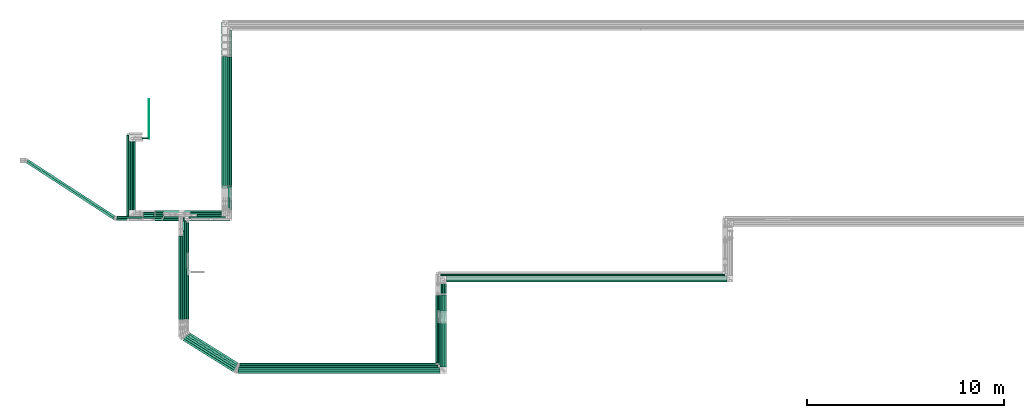
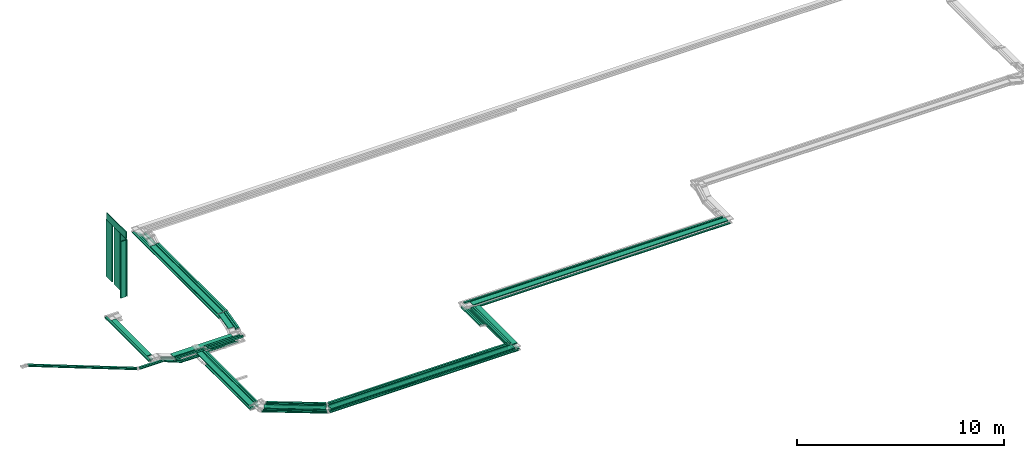
# One storey, part 1 of 14: 72 flow segments.
"""IFC2X3 building model written with IfcOpenShell, lengths in millimetres."""

from ifc_helpers import new_model, entity, si_unit, converted_unit, derived_unit, direction, frame, frame_2d, origin, origin_2d_with_axis, place, context, subcontext, project, spatial, rectangle, extrude, type_object, element, save


model = new_model("IFC2X3")

# Units and contexts
model_context = context("Model", 3, precision=0.01, world=origin(), true_north=direction((6.12303176911189e-17, 1.0)))
body_context = subcontext(model_context, "Body", "Model", "MODEL_VIEW")
ifc_project = project(units=[si_unit("LENGTHUNIT", "METRE", prefix="MILLI"), si_unit("AREAUNIT", "SQUARE_METRE"), si_unit("VOLUMEUNIT", "CUBIC_METRE"), converted_unit("PLANEANGLEUNIT", "DEGREE", entity("IfcRatioMeasure", 0.0174532925199433), si_unit("PLANEANGLEUNIT", "RADIAN"), dimensions=[0, 0, 0, 0, 0, 0, 0]), si_unit("MASSUNIT", "GRAM", prefix="KILO"), derived_unit("MASSDENSITYUNIT", [(si_unit("MASSUNIT", "GRAM", prefix="KILO"), 1), (si_unit("LENGTHUNIT", "METRE"), -3)]), derived_unit("MOMENTOFINERTIAUNIT", [(si_unit("LENGTHUNIT", "METRE"), 4)]), si_unit("TIMEUNIT", "SECOND"), si_unit("FREQUENCYUNIT", "HERTZ"), si_unit("THERMODYNAMICTEMPERATUREUNIT", "DEGREE_CELSIUS"), derived_unit("THERMALTRANSMITTANCEUNIT", [(si_unit("MASSUNIT", "GRAM", prefix="KILO"), 1), (si_unit("THERMODYNAMICTEMPERATUREUNIT", "KELVIN"), -1), (si_unit("TIMEUNIT", "SECOND"), -3)]), derived_unit("VOLUMETRICFLOWRATEUNIT", [(si_unit("LENGTHUNIT", "METRE"), 3), (si_unit("TIMEUNIT", "SECOND"), -1)]), derived_unit("MASSFLOWRATEUNIT", [(si_unit("MASSUNIT", "GRAM", prefix="KILO"), 1), (si_unit("TIMEUNIT", "SECOND"), -1)]), derived_unit("ROTATIONALFREQUENCYUNIT", [(si_unit("TIMEUNIT", "SECOND"), -1)]), si_unit("ELECTRICCURRENTUNIT", "AMPERE"), si_unit("ELECTRICVOLTAGEUNIT", "VOLT"), si_unit("POWERUNIT", "WATT"), si_unit("FORCEUNIT", "NEWTON", prefix="KILO"), si_unit("ILLUMINANCEUNIT", "LUX"), si_unit("LUMINOUSFLUXUNIT", "LUMEN"), si_unit("LUMINOUSINTENSITYUNIT", "CANDELA"), derived_unit("USERDEFINED", [(si_unit("MASSUNIT", "GRAM", prefix="KILO"), -1), (si_unit("LENGTHUNIT", "METRE"), -2), (si_unit("TIMEUNIT", "SECOND"), 3), (si_unit("LUMINOUSFLUXUNIT", "LUMEN"), 1)]), derived_unit("LINEARVELOCITYUNIT", [(si_unit("LENGTHUNIT", "METRE"), 1), (si_unit("TIMEUNIT", "SECOND"), -1)]), si_unit("PRESSUREUNIT", "PASCAL"), derived_unit("USERDEFINED", [(si_unit("LENGTHUNIT", "METRE"), -2), (si_unit("MASSUNIT", "GRAM", prefix="KILO"), 1), (si_unit("TIMEUNIT", "SECOND"), -2)]), derived_unit("LINEARFORCEUNIT", [(si_unit("MASSUNIT", "GRAM", prefix="KILO"), 1), (si_unit("LENGTHUNIT", "METRE"), 1), (si_unit("TIMEUNIT", "SECOND"), -2), (si_unit("LENGTHUNIT", "METRE"), -1)]), derived_unit("PLANARFORCEUNIT", [(si_unit("MASSUNIT", "GRAM", prefix="KILO"), 1), (si_unit("LENGTHUNIT", "METRE"), 1), (si_unit("TIMEUNIT", "SECOND"), -2), (si_unit("LENGTHUNIT", "METRE"), -2)])], contexts=[model_context])

# Site, building, storey
site_placement = place(None, origin())
site = spatial("IfcSite", under=ifc_project, at=site_placement, CompositionType="ELEMENT")
building_placement = place(site_placement, origin())
building = spatial("IfcBuilding", under=site, at=building_placement, CompositionType="ELEMENT")
storey_placement = place(building_placement, frame((0.0, 0.0, 19800.0)))
storey = spatial("IfcBuildingStorey", under=building, at=storey_placement, Name="06", CompositionType="ELEMENT", Elevation=19800.0)

# Flow segments
cable_carrier_segment_type_1 = type_object("IfcCableCarrierSegmentType", PredefinedType="CABLETRAYSEGMENT")
flow_segment_1_placement = place(storey_placement, frame((20190.22, 11603.0, 3300.0)))
element("IfcFlowSegment", 1, at=flow_segment_1_placement, inside=storey, type_object=cable_carrier_segment_type_1, context=body_context, shape_type="SweptSolid", body=[
    extrude(rectangle(XDim=6551.54787533766, YDim=300.000000000001, at=origin_2d_with_axis()), frame((150.0, 3275.77, 0.0), z_axis=(0.0, 0.0, 1.0), x_axis=(0.0, 1.0, 0.0)), (0.0, 0.0, 1.0), 49.9999999999973),
])
flow_segment_2_placement = place(storey_placement, frame((20495.22, 11609.12, 3300.0)))
element("IfcFlowSegment", 2, at=flow_segment_2_placement, inside=storey, type_object=cable_carrier_segment_type_1, context=body_context, shape_type="SweptSolid", body=[
    extrude(rectangle(XDim=6531.55992167095, YDim=100.000000000003, at=origin_2d_with_axis()), frame((50.0, 3265.78, 0.0), z_axis=(0.0, 0.0, 1.0), x_axis=(0.0, 1.0, 0.0)), (0.0, 0.0, 1.0), 100.000000000003),
])
flow_segment_3_placement = place(storey_placement, frame((20600.22, 11501.25, 3100.0)))
element("IfcFlowSegment", 3, at=flow_segment_3_placement, inside=storey, type_object=cable_carrier_segment_type_1, context=body_context, shape_type="SweptSolid", body=[
    extrude(rectangle(XDim=7968.74949015567, YDim=100.000000000003, at=origin_2d_with_axis()), frame((50.0, 3984.37, 0.0), z_axis=(0.0, 0.0, 1.0), x_axis=(0.0, -1.0, 0.0)), (0.0, 0.0, 1.0), 100.000000000003),
])
flow_segment_4_placement = place(storey_placement, frame((20190.22, 11493.51, 3100.0)))
element("IfcFlowSegment", 4, at=flow_segment_4_placement, inside=storey, type_object=cable_carrier_segment_type_1, context=body_context, shape_type="SweptSolid", body=[
    extrude(rectangle(XDim=8386.48782817678, YDim=100.000000000003, at=origin_2d_with_axis()), frame((50.0, 4193.24, 0.0), z_axis=(0.0, 0.0, 1.0), x_axis=(0.0, -1.0, 0.0)), (0.0, 0.0, 1.0), 49.9999999999973),
])
flow_segment_5_placement = place(storey_placement, frame((20295.22, 11493.51, 3100.0)))
element("IfcFlowSegment", 5, at=flow_segment_5_placement, inside=storey, type_object=cable_carrier_segment_type_1, context=body_context, shape_type="SweptSolid", body=[
    extrude(rectangle(XDim=8281.48782817677, YDim=100.000000000003, at=origin_2d_with_axis()), frame((50.0, 4140.74, 0.0), z_axis=(0.0, 0.0, 1.0), x_axis=(0.0, -1.0, 0.0)), (0.0, 0.0, 1.0), 49.9999999999973),
])
flow_segment_6_placement = place(storey_placement, frame((20400.22, 11493.51, 3100.0)))
element("IfcFlowSegment", 6, at=flow_segment_6_placement, inside=storey, type_object=cable_carrier_segment_type_1, context=body_context, shape_type="SweptSolid", body=[
    extrude(rectangle(XDim=8176.48782817679, YDim=100.000000000003, at=origin_2d_with_axis()), frame((50.0, 4088.24, 0.0), z_axis=(0.0, 0.0, 1.0), x_axis=(0.0, -1.0, 0.0)), (0.0, 0.0, 1.0), 49.9999999999973),
])
flow_segment_7_placement = place(storey_placement, frame((18157.54, 10050.13, 2900.0)))
element("IfcFlowSegment", 7, at=flow_segment_7_placement, inside=storey, type_object=cable_carrier_segment_type_1, context=body_context, shape_type="SweptSolid", body=[
    extrude(rectangle(XDim=2012.67275358651, YDim=300.000000000001, at=origin_2d_with_axis()), frame((1006.34, 150.0, 0.0), z_axis=(0.0, 0.0, 1.0), x_axis=(-1.0, 0.0, 0.0)), (0.0, 0.0, 1.0), 49.9999999999973),
])
flow_segment_8_placement = place(storey_placement, frame((18522.14, 9944.24, 2900.0)))
element("IfcFlowSegment", 8, at=flow_segment_8_placement, inside=storey, type_object=cable_carrier_segment_type_1, context=body_context, shape_type="SweptSolid", body=[
    extrude(rectangle(XDim=1953.07275358647, YDim=99.9999999999989, at=origin_2d_with_axis()), frame((976.54, 50.0, 0.0), z_axis=(0.0, 0.0, 1.0), x_axis=(-1.0, 0.0, 0.0)), (0.0, 0.0, 1.0), 100.000000000003),
])
flow_segment_9_placement = place(storey_placement, frame((16789.0, 9824.22, 2900.0)))
element("IfcFlowSegment", 9, at=flow_segment_9_placement, inside=storey, type_object=cable_carrier_segment_type_1, context=body_context, shape_type="SweptSolid", body=[
    extrude(rectangle(XDim=1677.74327889368, YDim=99.9999999999989, at=origin_2d_with_axis()), frame((838.87, 50.0, 0.0)), (0.0, 0.0, 1.0), 100.000000000003),
])
flow_segment_10_placement = place(storey_placement, frame((17191.35, 9840.23, 2600.0)))
element("IfcFlowSegment", 10, at=flow_segment_10_placement, inside=storey, type_object=cable_carrier_segment_type_1, context=body_context, shape_type="SweptSolid", body=[
    extrude(rectangle(XDim=1095.79181857732, YDim=99.9999999999989, at=origin_2d_with_axis()), frame((547.9, 50.0, 0.0)), (0.0, 0.0, 1.0), 49.9999999999973),
])
flow_segment_11_placement = place(storey_placement, frame((17256.59, 9944.24, 2600.0)))
element("IfcFlowSegment", 11, at=flow_segment_11_placement, inside=storey, type_object=cable_carrier_segment_type_1, context=body_context, shape_type="SweptSolid", body=[
    extrude(rectangle(XDim=3123.62777329295, YDim=99.9999999999989, at=origin_2d_with_axis()), frame((1561.81, 50.0, 0.0), z_axis=(0.0, 0.0, 1.0), x_axis=(-1.0, 0.0, 0.0)), (0.0, 0.0, 1.0), 50.0000000000016),
])
flow_segment_12_placement = place(storey_placement, frame((31591.43, 6717.78, 2800.0)))
element("IfcFlowSegment", 12, at=flow_segment_12_placement, inside=storey, type_object=cable_carrier_segment_type_1, context=body_context, shape_type="SweptSolid", body=[
    extrude(rectangle(XDim=14204.952720189, YDim=300.000000000001, at=origin_2d_with_axis()), frame((7102.48, 150.0, 0.0), z_axis=(0.0, 0.0, 1.0), x_axis=(-1.0, 0.0, 0.0)), (0.0, 0.0, 1.0), 49.9999999999973),
])
flow_segment_13_placement = place(storey_placement, frame((31280.61, 7021.93, 2800.0)))
element("IfcFlowSegment", 13, at=flow_segment_13_placement, inside=storey, type_object=cable_carrier_segment_type_1, context=body_context, shape_type="SweptSolid", body=[
    extrude(rectangle(XDim=14408.678815753, YDim=100.000000000001, at=origin_2d_with_axis()), frame((7204.34, 50.0, 0.0), z_axis=(0.0, 0.0, 1.0), x_axis=(-1.0, 0.0, 0.0)), (0.0, 0.0, 1.0), 100.000000000003),
])
flow_segment_14_placement = place(storey_placement, frame((31591.43, 6717.78, 2600.0)))
element("IfcFlowSegment", 14, at=flow_segment_14_placement, inside=storey, type_object=cable_carrier_segment_type_1, context=body_context, shape_type="SweptSolid", body=[
    extrude(rectangle(XDim=14323.3274230858, YDim=99.9999999999989, at=origin_2d_with_axis()), frame((7161.66, 50.0, 0.0), z_axis=(0.0, 0.0, 1.0), x_axis=(-1.0, 0.0, 0.0)), (0.0, 0.0, 1.0), 50.0000000000016),
])
flow_segment_15_placement = place(storey_placement, frame((21062.59, 2392.27, 3200.0)))
element("IfcFlowSegment", 15, at=flow_segment_15_placement, inside=storey, type_object=cable_carrier_segment_type_1, context=body_context, shape_type="SweptSolid", body=[
    extrude(rectangle(XDim=10078.0137037583, YDim=100.0, at=origin_2d_with_axis()), frame((5039.01, 50.0, 0.0), z_axis=(0.0, 0.0, 1.0), x_axis=(-1.0, 0.0, 0.0)), (0.0, 0.0, 1.0), 100.000000000008),
])
flow_segment_16_placement = place(storey_placement, frame((20986.65, 2192.27, 3000.0)))
element("IfcFlowSegment", 16, at=flow_segment_16_placement, inside=storey, type_object=cable_carrier_segment_type_1, context=body_context, shape_type="SweptSolid", body=[
    extrude(rectangle(XDim=10354.846485042, YDim=100.0, at=origin_2d_with_axis()), frame((5177.42, 50.0, 0.0), z_axis=(0.0, 0.0, 1.0), x_axis=(-1.0, 0.0, 0.0)), (0.0, 0.0, 1.0), 49.9999999999973),
])
flow_segment_17_placement = place(storey_placement, frame((18007.14, 4795.41, 2800.0)))
element("IfcFlowSegment", 17, at=flow_segment_17_placement, inside=storey, type_object=cable_carrier_segment_type_1, context=body_context, shape_type="SweptSolid", body=[
    extrude(rectangle(XDim=5199.72119742787, YDim=300.000000000001, at=origin_2d_with_axis()), frame((150.0, 2599.86, 0.0), z_axis=(0.0, 0.0, 1.0), x_axis=(0.0, 1.0, 0.0)), (0.0, 0.0, 1.0), 49.9999999999973),
])
flow_segment_18_placement = place(storey_placement, frame((18312.14, 4839.93, 2800.0)))
element("IfcFlowSegment", 18, at=flow_segment_18_placement, inside=storey, type_object=cable_carrier_segment_type_1, context=body_context, shape_type="SweptSolid", body=[
    extrude(rectangle(XDim=5127.14874316907, YDim=99.9999999999989, at=origin_2d_with_axis()), frame((50.0, 2563.57, 0.0), z_axis=(0.0, 0.0, 1.0), x_axis=(0.0, 1.0, 0.0)), (0.0, 0.0, 1.0), 100.000000000003),
])
flow_segment_19_placement = place(storey_placement, frame((18417.14, 8193.95, 2600.0)))
element("IfcFlowSegment", 19, at=flow_segment_19_placement, inside=storey, type_object=cable_carrier_segment_type_1, context=body_context, shape_type="SweptSolid", body=[
    extrude(rectangle(XDim=1516.27528069827, YDim=99.9999999999989, at=origin_2d_with_axis()), frame((50.0, 758.14, 0.0), z_axis=(0.0, 0.0, 1.0), x_axis=(0.0, -1.0, 0.0)), (0.0, 0.0, 1.0), 50.0000000000016),
])
flow_segment_20_placement = place(storey_placement, frame((18007.14, 4732.08, 2600.0)))
element("IfcFlowSegment", 20, at=flow_segment_20_placement, inside=storey, type_object=cable_carrier_segment_type_1, context=body_context, shape_type="SweptSolid", body=[
    extrude(rectangle(XDim=4319.69591813559, YDim=99.9999999999989, at=origin_2d_with_axis()), frame((50.0, 2159.85, 0.0), z_axis=(0.0, 0.0, 1.0), x_axis=(0.0, 1.0, 0.0)), (0.0, 0.0, 1.0), 49.9999999999973),
])
flow_segment_21_placement = place(storey_placement, frame((18112.14, 4732.08, 2600.0)))
element("IfcFlowSegment", 21, at=flow_segment_21_placement, inside=storey, type_object=cable_carrier_segment_type_1, context=body_context, shape_type="SweptSolid", body=[
    extrude(rectangle(XDim=4319.6959181356, YDim=99.9999999999989, at=origin_2d_with_axis()), frame((50.0, 2159.85, 0.0), z_axis=(0.0, 0.0, 1.0), x_axis=(0.0, 1.0, 0.0)), (0.0, 0.0, 1.0), 49.9999999999973),
])
flow_segment_22_placement = place(storey_placement, frame((18217.14, 4732.08, 2600.0)))
element("IfcFlowSegment", 22, at=flow_segment_22_placement, inside=storey, type_object=cable_carrier_segment_type_1, context=body_context, shape_type="SweptSolid", body=[
    extrude(rectangle(XDim=4546.36734918782, YDim=99.9999999999989, at=origin_2d_with_axis()), frame((50.0, 2273.18, 0.0), z_axis=(0.0, 0.0, 1.0), x_axis=(0.0, 1.0, 0.0)), (0.0, 0.0, 1.0), 49.9999999999973),
])
flow_segment_23_placement = place(storey_placement, frame((31125.11, 2617.27, 3000.0)))
element("IfcFlowSegment", 23, at=flow_segment_23_placement, inside=storey, type_object=cable_carrier_segment_type_1, context=body_context, shape_type="SweptSolid", body=[
    extrude(rectangle(XDim=2031.89362716771, YDim=100.000000000003, at=origin_2d_with_axis()), frame((50.0, 1015.95, 0.0), z_axis=(0.0, 0.0, 1.0), x_axis=(0.0, 1.0, 0.0)), (0.0, 0.0, 1.0), 99.9999999999989),
])
flow_segment_24_placement = place(storey_placement, frame((31125.11, 5296.63, 2600.0)))
element("IfcFlowSegment", 24, at=flow_segment_24_placement, inside=storey, type_object=cable_carrier_segment_type_1, context=body_context, shape_type="SweptSolid", body=[
    extrude(rectangle(XDim=1808.36637507826, YDim=100.000000000003, at=origin_2d_with_axis()), frame((50.0, 904.18, 0.0), z_axis=(0.0, 0.0, 1.0), x_axis=(0.0, 1.0, 0.0)), (0.0, 0.0, 1.0), 100.000000000003),
])
flow_segment_25_placement = place(storey_placement, frame((31249.29, 5245.16, 2600.0)))
element("IfcFlowSegment", 25, at=flow_segment_25_placement, inside=storey, type_object=cable_carrier_segment_type_1, context=body_context, shape_type="SweptSolid", body=[
    extrude(rectangle(XDim=1662.61404192942, YDim=100.000000000003, at=origin_2d_with_axis()), frame((50.0, 831.31, 0.0), z_axis=(0.0, 0.0, 1.0), x_axis=(0.0, -1.0, 0.0)), (0.0, 0.0, 1.0), 49.9999999999973),
])
flow_segment_26_placement = place(storey_placement, frame((31249.29, 2417.27, 3000.0)))
element("IfcFlowSegment", 26, at=flow_segment_26_placement, inside=storey, type_object=cable_carrier_segment_type_1, context=body_context, shape_type="SweptSolid", body=[
    extrude(rectangle(XDim=2211.95486644315, YDim=100.000000000003, at=origin_2d_with_axis()), frame((50.0, 1105.98, 0.0), z_axis=(0.0, 0.0, 1.0), x_axis=(0.0, 1.0, 0.0)), (0.0, 0.0, 1.0), 49.9999999999973),
])
flow_segment_27_placement = place(storey_placement, frame((31361.5, 5245.16, 2600.0)))
element("IfcFlowSegment", 27, at=flow_segment_27_placement, inside=storey, type_object=cable_carrier_segment_type_1, context=body_context, shape_type="SweptSolid", body=[
    extrude(rectangle(XDim=1557.61404192941, YDim=100.000000000003, at=origin_2d_with_axis()), frame((50.0, 778.81, 0.0), z_axis=(0.0, 0.0, 1.0), x_axis=(0.0, -1.0, 0.0)), (0.0, 0.0, 1.0), 49.9999999999973),
])
flow_segment_28_placement = place(storey_placement, frame((31361.5, 2312.27, 3000.0)))
element("IfcFlowSegment", 28, at=flow_segment_28_placement, inside=storey, type_object=cable_carrier_segment_type_1, context=body_context, shape_type="SweptSolid", body=[
    extrude(rectangle(XDim=2316.95486644316, YDim=100.000000000003, at=origin_2d_with_axis()), frame((50.0, 1158.48, 0.0), z_axis=(0.0, 0.0, 1.0), x_axis=(0.0, -1.0, 0.0)), (0.0, 0.0, 1.0), 49.9999999999973),
])
flow_segment_29_placement = place(storey_placement, frame((31471.43, 5245.16, 2600.0)))
element("IfcFlowSegment", 29, at=flow_segment_29_placement, inside=storey, type_object=cable_carrier_segment_type_1, context=body_context, shape_type="SweptSolid", body=[
    extrude(rectangle(XDim=1452.61404192941, YDim=100.000000000003, at=origin_2d_with_axis()), frame((50.0, 726.31, 0.0), z_axis=(0.0, 0.0, 1.0), x_axis=(0.0, -1.0, 0.0)), (0.0, 0.0, 1.0), 49.9999999999973),
])
flow_segment_30_placement = place(storey_placement, frame((31471.43, 2207.27, 3000.0)))
element("IfcFlowSegment", 30, at=flow_segment_30_placement, inside=storey, type_object=cable_carrier_segment_type_1, context=body_context, shape_type="SweptSolid", body=[
    extrude(rectangle(XDim=2421.95486644317, YDim=100.000000000003, at=origin_2d_with_axis()), frame((50.0, 1210.98, 0.0), z_axis=(0.0, 0.0, 1.0), x_axis=(0.0, 1.0, 0.0)), (0.0, 0.0, 1.0), 49.9999999999973),
])
flow_segment_31_placement = place(storey_placement, frame((31271.43, 2407.27, 3200.0)))
element("IfcFlowSegment", 31, at=flow_segment_31_placement, inside=storey, type_object=cable_carrier_segment_type_1, context=body_context, shape_type="SweptSolid", body=[
    extrude(rectangle(XDim=3662.65856661165, YDim=300.000000000001, at=origin_2d_with_axis()), frame((150.0, 1831.33, 0.0), z_axis=(0.0, 0.0, 1.0), x_axis=(0.0, 1.0, 0.0)), (0.0, 0.0, 1.0), 49.9999999999973),
])
flow_segment_32_placement = place(storey_placement, frame((31160.61, 2512.27, 3200.0)))
element("IfcFlowSegment", 32, at=flow_segment_32_placement, inside=storey, type_object=cable_carrier_segment_type_1, context=body_context, shape_type="SweptSolid", body=[
    extrude(rectangle(XDim=3526.8936271677, YDim=100.000000000003, at=origin_2d_with_axis()), frame((50.0, 1763.45, 0.0), z_axis=(0.0, 0.0, 1.0), x_axis=(0.0, 1.0, 0.0)), (0.0, 0.0, 1.0), 100.000000000003),
])
flow_segment_33_placement = place(storey_placement, frame((31047.89, 2620.0, 3200.0)))
element("IfcFlowSegment", 33, at=flow_segment_33_placement, inside=storey, type_object=cable_carrier_segment_type_1, context=body_context, shape_type="SweptSolid", body=[
    extrude(rectangle(XDim=3419.24047842777, YDim=100.000000000003, at=origin_2d_with_axis()), frame((50.0, 1709.62, 0.0), z_axis=(0.0, 0.0, 1.0), x_axis=(0.0, 1.0, 0.0)), (0.0, 0.0, 1.0), 100.000000000008),
])
flow_segment_34_placement = place(storey_placement, frame((21097.29, 2497.27, 3000.0)))
element("IfcFlowSegment", 34, at=flow_segment_34_placement, inside=storey, type_object=cable_carrier_segment_type_1, context=body_context, shape_type="SweptSolid", body=[
    extrude(rectangle(XDim=10007.8208838715, YDim=100.0, at=origin_2d_with_axis()), frame((5003.91, 50.0, 0.0), z_axis=(0.0, 0.0, 1.0), x_axis=(-1.0, 0.0, 0.0)), (0.0, 0.0, 1.0), 100.000000000003),
])
flow_segment_35_placement = place(storey_placement, frame((18430.51, 2430.79, 3200.0)))
element("IfcFlowSegment", 35, at=flow_segment_35_placement, inside=storey, type_object=cable_carrier_segment_type_1, context=body_context, shape_type="SweptSolid", body=[
    extrude(rectangle(XDim=2945.29672939392, YDim=100.000000000004, at=origin_2d_with_axis()), frame((1275.37, 822.79, 0.0), z_axis=(0.0, 0.0, 1.0), x_axis=(-0.848048096156423, 0.52991926423321, 0.0)), (0.0, 0.0, 1.0), 100.000000000003),
])
flow_segment_36_placement = place(storey_placement, frame((21014.25, 2297.27, 3000.0)))
element("IfcFlowSegment", 36, at=flow_segment_36_placement, inside=storey, type_object=cable_carrier_segment_type_1, context=body_context, shape_type="SweptSolid", body=[
    extrude(rectangle(XDim=10215.0397317824, YDim=100.0, at=origin_2d_with_axis()), frame((5107.52, 50.0, 0.0), z_axis=(0.0, 0.0, 1.0), x_axis=(-1.0, 0.0, 0.0)), (0.0, 0.0, 1.0), 49.9999999999973),
])
flow_segment_37_placement = place(storey_placement, frame((20950.04, 2087.27, 3000.0)))
element("IfcFlowSegment", 37, at=flow_segment_37_placement, inside=storey, type_object=cable_carrier_segment_type_1, context=body_context, shape_type="SweptSolid", body=[
    extrude(rectangle(XDim=10501.3978164659, YDim=100.0, at=origin_2d_with_axis()), frame((5250.7, 50.0, 0.0), z_axis=(0.0, 0.0, 1.0), x_axis=(-1.0, 0.0, 0.0)), (0.0, 0.0, 1.0), 49.9999999999973),
])
flow_segment_38_placement = place(storey_placement, frame((18125.51, 2125.79, 3000.0)))
element("IfcFlowSegment", 38, at=flow_segment_38_placement, inside=storey, type_object=cable_carrier_segment_type_1, context=body_context, shape_type="SweptSolid", body=[
    extrude(rectangle(XDim=3172.2205568259, YDim=100.000000000005, at=origin_2d_with_axis()), frame((1371.59, 882.91, 0.0), z_axis=(0.0, 0.0, 1.0), x_axis=(-0.848048096156423, 0.52991926423321, 0.0)), (0.0, 0.0, 1.0), 49.9999999999973),
])
flow_segment_39_placement = place(storey_placement, frame((21002.32, 2087.27, 3200.0)))
element("IfcFlowSegment", 39, at=flow_segment_39_placement, inside=storey, type_object=cable_carrier_segment_type_1, context=body_context, shape_type="SweptSolid", body=[
    extrude(rectangle(XDim=10249.1129852784, YDim=300.0, at=origin_2d_with_axis()), frame((5124.56, 150.0, 0.0), z_axis=(0.0, 0.0, 1.0), x_axis=(-1.0, 0.0, 0.0)), (0.0, 0.0, 1.0), 49.9999999999973),
])
flow_segment_40_placement = place(storey_placement, frame((21092.92, 2500.0, 3200.0)))
element("IfcFlowSegment", 40, at=flow_segment_40_placement, inside=storey, type_object=cable_carrier_segment_type_1, context=body_context, shape_type="SweptSolid", body=[
    extrude(rectangle(XDim=9934.97609200436, YDim=100.0, at=origin_2d_with_axis()), frame((4967.49, 50.0, 0.0), z_axis=(0.0, 0.0, 1.0), x_axis=(-1.0, 0.0, 0.0)), (0.0, 0.0, 1.0), 100.000000000008),
])
flow_segment_41_placement = place(storey_placement, frame((18535.51, 2538.52, 3200.0)))
element("IfcFlowSegment", 41, at=flow_segment_41_placement, inside=storey, type_object=cable_carrier_segment_type_1, context=body_context, shape_type="SweptSolid", body=[
    extrude(rectangle(XDim=2857.23886438621, YDim=100.000000000005, at=origin_2d_with_axis()), frame((1238.03, 799.46, 0.0), z_axis=(0.0, 0.0, 1.0), x_axis=(-0.84804809615642, 0.529919264233215, 0.0)), (0.0, 0.0, 1.0), 100.000000000003),
])
flow_segment_42_placement = place(storey_placement, frame((18230.51, 2230.79, 3000.0)))
element("IfcFlowSegment", 42, at=flow_segment_42_placement, inside=storey, type_object=cable_carrier_segment_type_1, context=body_context, shape_type="SweptSolid", body=[
    extrude(rectangle(XDim=3091.5847138092, YDim=100.000000000005, at=origin_2d_with_axis()), frame((1337.4, 861.55, 0.0), z_axis=(0.0, 0.0, 1.0), x_axis=(-0.848048096156424, 0.529919264233208, 0.0)), (0.0, 0.0, 1.0), 49.9999999999973),
])
flow_segment_43_placement = place(storey_placement, frame((18335.51, 2335.79, 3000.0)))
element("IfcFlowSegment", 43, at=flow_segment_43_placement, inside=storey, type_object=cable_carrier_segment_type_1, context=body_context, shape_type="SweptSolid", body=[
    extrude(rectangle(XDim=3000.30868914057, YDim=100.000000000005, at=origin_2d_with_axis()), frame((1298.7, 837.36, 0.0), z_axis=(0.0, 0.0, 1.0), x_axis=(-0.848048096156424, 0.529919264233208, 0.0)), (0.0, 0.0, 1.0), 49.9999999999973),
])
flow_segment_44_placement = place(storey_placement, frame((18535.51, 2535.79, 3000.0)))
element("IfcFlowSegment", 44, at=flow_segment_44_placement, inside=storey, type_object=cable_carrier_segment_type_1, context=body_context, shape_type="SweptSolid", body=[
    extrude(rectangle(XDim=2862.39408159168, YDim=99.9999999999956, at=origin_2d_with_axis()), frame((1240.22, 800.82, 0.0), z_axis=(0.0, 0.0, 1.0), x_axis=(-0.848048096156425, 0.529919264233207, 0.0)), (0.0, 0.0, 1.0), 100.000000000003),
])
flow_segment_45_placement = place(storey_placement, frame((18219.53, 2156.18, 3200.0)))
element("IfcFlowSegment", 45, at=flow_segment_45_placement, inside=storey, type_object=cable_carrier_segment_type_1, context=body_context, shape_type="SweptSolid", body=[
    extrude(rectangle(XDim=2998.03801991332, YDim=300.000000000004, at=origin_2d_with_axis()), frame((1350.73, 921.57, 0.0), z_axis=(0.0, 0.0, 1.0), x_axis=(-0.848048096156424, 0.529919264233208, 0.0)), (0.0, 0.0, 1.0), 49.9999999999973),
])
flow_segment_46_placement = place(storey_placement, frame((20600.22, 11609.12, 3300.0)))
element("IfcFlowSegment", 46, at=flow_segment_46_placement, inside=storey, type_object=cable_carrier_segment_type_1, context=body_context, shape_type="SweptSolid", body=[
    extrude(rectangle(XDim=6531.55992167089, YDim=100.000000000003, at=origin_2d_with_axis()), frame((50.0, 3265.78, 0.0), z_axis=(0.0, 0.0, 1.0), x_axis=(0.0, 1.0, 0.0)), (0.0, 0.0, 1.0), 100.000000000003),
])
flow_segment_47_placement = place(storey_placement, frame((20600.22, 10390.08, 3005.86)))
element("IfcFlowSegment", 47, at=flow_segment_47_placement, inside=storey, type_object=cable_carrier_segment_type_1, context=body_context, shape_type="SweptSolid", body=[
    extrude(rectangle(XDim=99.9999999999975, YDim=1207.4663906893, at=frame_2d((0.0, 0.0), x_axis=(0.0, 1.0))), frame((0.0, 597.96, 194.18), z_axis=(1.0, 0.0, 0.0), x_axis=(0.0, 0.970462347809245, 0.241252630005495)), (0.0, 0.0, 1.0), 100.000000000003),
])
flow_segment_48_placement = place(storey_placement, frame((20495.22, 10390.08, 3005.86)))
element("IfcFlowSegment", 48, at=flow_segment_48_placement, inside=storey, type_object=cable_carrier_segment_type_1, context=body_context, shape_type="SweptSolid", body=[
    extrude(rectangle(XDim=99.999999999998, YDim=1207.46639068923, at=frame_2d((0.0, 0.0), x_axis=(0.0, 1.0))), frame((0.0, 597.96, 194.18), z_axis=(1.0, 0.0, 0.0), x_axis=(0.0, -0.970462347809245, -0.241252630005494)), (0.0, 0.0, 1.0), 99.9999999999989),
])
flow_segment_49_placement = place(storey_placement, frame((20190.22, 10586.87, 3052.55)))
element("IfcFlowSegment", 49, at=flow_segment_49_placement, inside=storey, type_object=cable_carrier_segment_type_1, context=body_context, shape_type="SweptSolid", body=[
    extrude(rectangle(XDim=50.0000000000032, YDim=1017.02134440409, at=frame_2d((0.0, 0.0), x_axis=(0.0, 1.0))), frame((0.0, 499.52, 146.94), z_axis=(1.0, 0.0, 0.0), x_axis=(0.0, -0.970462347809243, -0.241252630005501)), (0.0, 0.0, 1.0), 300.000000000001),
])
flow_segment_50_placement = place(storey_placement, frame((16196.74, 10152.84, 2607.02)))
element("IfcFlowSegment", 50, at=flow_segment_50_placement, inside=storey, type_object=cable_carrier_segment_type_1, context=body_context, shape_type="SweptSolid", body=[
    extrude(rectangle(XDim=49.9999999999978, YDim=99.9999999999989, at=origin_2d_with_axis()), frame((8.9, 50.0, 412.6), z_axis=(0.934483298097407, 0.0, -0.356006974056679), x_axis=(0.356006974056679, 0.0, 0.934483298097407)), (0.0, 0.0, 1.0), 1093.32996658713),
])
for number, where in (
    (51, (16196.74, 10049.82, 2607.02)),
    (52, (16196.74, 9944.24, 2607.02)),
):
    element("IfcFlowSegment", number, at=place(storey_placement, frame(where)), inside=storey, type_object=cable_carrier_segment_type_1, context=body_context, shape_type="SweptSolid", body=[
        extrude(rectangle(XDim=49.9999999999978, YDim=99.9999999999989, at=origin_2d_with_axis()), frame((8.9, 50.0, 412.6), z_axis=(0.934483298097407, 0.0, -0.356006974056679), x_axis=(0.356006974056679, 0.0, 0.934483298097407)), (0.0, 0.0, 1.0), 1093.32996658708),
    ])
flow_segment_51_placement = place(storey_placement, frame((14864.6, 9944.24, 3000.0)))
element("IfcFlowSegment", 53, at=flow_segment_51_placement, inside=storey, type_object=cable_carrier_segment_type_1, context=body_context, shape_type="SweptSolid", body=[
    extrude(rectangle(XDim=1311.78382857603, YDim=99.9999999999989, at=origin_2d_with_axis()), frame((655.89, 50.0, 0.0), z_axis=(0.0, 0.0, 1.0), x_axis=(-1.0, 0.0, 0.0)), (0.0, 0.0, 1.0), 49.9999999999973),
])
flow_segment_52_placement = place(storey_placement, frame((16163.82, 9840.23, 2607.48)))
element("IfcFlowSegment", 54, at=flow_segment_52_placement, inside=storey, type_object=cable_carrier_segment_type_1, context=body_context, shape_type="SweptSolid", body=[
    extrude(rectangle(XDim=49.9999999999963, YDim=99.9999999999989, at=origin_2d_with_axis()), frame((9.22, 50.0, 415.2), z_axis=(0.929573625278576, 0.0, -0.368636508211606), x_axis=(0.368636508211606, 0.0, 0.929573625278576)), (0.0, 0.0, 1.0), 1063.2806215525),
])
flow_segment_53_placement = place(storey_placement, frame((18467.54, 9824.22, 2900.0)))
element("IfcFlowSegment", 55, at=flow_segment_53_placement, inside=storey, type_object=cable_carrier_segment_type_1, context=body_context, shape_type="SweptSolid", body=[
    extrude(rectangle(XDim=2112.67275358652, YDim=99.9999999999989, at=origin_2d_with_axis()), frame((1056.34, 50.0, 0.0), z_axis=(0.0, 0.0, 1.0), x_axis=(-1.0, 0.0, 0.0)), (0.0, 0.0, 1.0), 100.000000000003),
])
flow_segment_54_placement = place(storey_placement, frame((18417.14, 4776.6, 2600.0)))
element("IfcFlowSegment", 56, at=flow_segment_54_placement, inside=storey, type_object=cable_carrier_segment_type_1, context=body_context, shape_type="SweptSolid", body=[
    extrude(rectangle(XDim=2267.1487431691, YDim=99.9999999999989, at=origin_2d_with_axis()), frame((50.0, 1133.57, 0.0), z_axis=(0.0, 0.0, 1.0), x_axis=(0.0, 1.0, 0.0)), (0.0, 0.0, 1.0), 100.000000000003),
])
flow_segment_55_placement = place(storey_placement, frame((18917.46, 10049.82, 2600.0)))
element("IfcFlowSegment", 57, at=flow_segment_55_placement, inside=storey, type_object=cable_carrier_segment_type_1, context=body_context, shape_type="SweptSolid", body=[
    extrude(rectangle(XDim=1357.75911263266, YDim=99.9999999999989, at=origin_2d_with_axis()), frame((678.88, 50.0, 0.0), z_axis=(0.0, 0.0, 1.0), x_axis=(-1.0, 0.0, 0.0)), (0.0, 0.0, 1.0), 49.9999999999973),
])
flow_segment_56_placement = place(storey_placement, frame((18587.97, 10152.84, 2600.0)))
element("IfcFlowSegment", 58, at=flow_segment_56_placement, inside=storey, type_object=cable_carrier_segment_type_1, context=body_context, shape_type="SweptSolid", body=[
    extrude(rectangle(XDim=1582.24295872755, YDim=99.9999999999989, at=origin_2d_with_axis()), frame((791.12, 50.0, 0.0), z_axis=(0.0, 0.0, 1.0), x_axis=(-1.0, 0.0, 0.0)), (0.0, 0.0, 1.0), 49.9999999999973),
])
flow_segment_57_placement = place(storey_placement, frame((16817.98, 10050.13, 2900.0)))
element("IfcFlowSegment", 59, at=flow_segment_57_placement, inside=storey, type_object=cable_carrier_segment_type_1, context=body_context, shape_type="SweptSolid", body=[
    extrude(rectangle(XDim=1338.76398992904, YDim=300.000000000001, at=origin_2d_with_axis()), frame((669.38, 150.0, 0.0)), (0.0, 0.0, 1.0), 50.0000000000016),
])
flow_segment_58_placement = place(storey_placement, frame((15490.0, 10370.13, 3200.0)))
element("IfcFlowSegment", 60, at=flow_segment_58_placement, inside=storey, type_object=cable_carrier_segment_type_1, context=body_context, shape_type="SweptSolid", body=[
    extrude(rectangle(XDim=3460.0, YDim=300.000000000001, at=origin_2d_with_axis()), frame((150.0, 1730.0, 0.0), z_axis=(0.0, 0.0, 1.0), x_axis=(0.0, 1.0, 0.0)), (0.0, 0.0, 1.0), 49.9999999999973),
])
flow_segment_59_placement = place(storey_placement, frame((15378.62, 9944.22, 3200.0)))
element("IfcFlowSegment", 61, at=flow_segment_59_placement, inside=storey, type_object=cable_carrier_segment_type_1, context=body_context, shape_type="SweptSolid", body=[
    extrude(rectangle(XDim=4216.00503583277, YDim=99.9999999999989, at=origin_2d_with_axis()), frame((50.0, 2108.0, 0.0), z_axis=(0.0, 0.0, 1.0), x_axis=(0.0, 1.0, 0.0)), (0.0, 0.0, 1.0), 100.000000000003),
])
flow_segment_60_placement = place(storey_placement, frame((15690.0, 10272.84, 3000.0)))
element("IfcFlowSegment", 62, at=flow_segment_60_placement, inside=storey, type_object=cable_carrier_segment_type_1, context=body_context, shape_type="SweptSolid", body=[
    extrude(rectangle(XDim=3557.28750820052, YDim=99.9999999999989, at=origin_2d_with_axis()), frame((50.0, 1778.64, 0.0), z_axis=(0.0, 0.0, 1.0), x_axis=(0.0, 1.0, 0.0)), (0.0, 0.0, 1.0), 49.9999999999973),
])
flow_segment_61_placement = place(storey_placement, frame((15581.77, 10169.82, 3000.0)))
element("IfcFlowSegment", 63, at=flow_segment_61_placement, inside=storey, type_object=cable_carrier_segment_type_1, context=body_context, shape_type="SweptSolid", body=[
    extrude(rectangle(XDim=3765.11562472394, YDim=99.9999999999989, at=origin_2d_with_axis()), frame((50.0, 1882.56, 0.0), z_axis=(0.0, 0.0, 1.0), x_axis=(0.0, 1.0, 0.0)), (0.0, 0.0, 1.0), 49.9999999999973),
])
flow_segment_62_placement = place(storey_placement, frame((10298.83, 9985.11, 3000.0)))
element("IfcFlowSegment", 64, at=flow_segment_62_placement, inside=storey, type_object=cable_carrier_segment_type_1, context=body_context, shape_type="SweptSolid", body=[
    extrude(rectangle(XDim=5279.51460201519, YDim=99.9999999999984, at=origin_2d_with_axis()), frame((2241.12, 1479.65, 0.0), z_axis=(0.0, 0.0, 1.0), x_axis=(-0.838670567945421, 0.544639035015032, 0.0)), (0.0, 0.0, 1.0), 49.9999999999973),
])
flow_segment_63_placement = place(storey_placement, frame((14826.45, 9840.23, 3003.4)))
element("IfcFlowSegment", 65, at=flow_segment_63_placement, inside=storey, type_object=cable_carrier_segment_type_1, context=body_context, shape_type="SweptSolid", body=[
    extrude(rectangle(XDim=1316.6631120587, YDim=99.9999999999989, at=origin_2d_with_axis()), frame((658.33, 50.0, 0.0), z_axis=(0.0, 0.0, 1.0), x_axis=(-1.0, 0.0, 0.0)), (0.0, 0.0, 1.0), 49.9999999999973),
])
flow_segment_64_placement = place(storey_placement, frame((10280.65, 9881.1, 3003.4)))
element("IfcFlowSegment", 66, at=flow_segment_64_placement, inside=storey, type_object=cable_carrier_segment_type_1, context=body_context, shape_type="SweptSolid", body=[
    extrude(rectangle(XDim=5255.69129290911, YDim=99.9999999999985, at=origin_2d_with_axis()), frame((2231.13, 1473.16, 0.0), z_axis=(0.0, 0.0, 1.0), x_axis=(-0.83867056794542, 0.544639035015034, 0.0)), (0.0, 0.0, 1.0), 49.9999999999973),
])
flow_segment_65_placement = place(storey_placement, frame((18417.14, 4839.93, 2800.0)))
element("IfcFlowSegment", 67, at=flow_segment_65_placement, inside=storey, type_object=cable_carrier_segment_type_1, context=body_context, shape_type="SweptSolid", body=[
    extrude(rectangle(XDim=4879.29374874634, YDim=99.9999999999989, at=origin_2d_with_axis()), frame((50.0, 2439.65, 0.0), z_axis=(0.0, 0.0, 1.0), x_axis=(0.0, 1.0, 0.0)), (0.0, 0.0, 1.0), 100.000000000003),
])
cable_carrier_segment_type_2 = type_object("IfcCableCarrierSegmentType", PredefinedType="CABLETRAYSEGMENT")
for number, where in (
    (68, (16472.31, 15387.61, 4225.84)),
    (69, (16472.31, 14607.61, 4225.84)),
):
    element("IfcFlowSegment", number, at=place(storey_placement, frame(where)), inside=storey, type_object=cable_carrier_segment_type_2, context=body_context, shape_type="SweptSolid", body=[
        extrude(rectangle(XDim=50.0000000000016, YDim=600.000000000002, at=origin_2d_with_axis()), frame((25.0, 300.0, 0.0), z_axis=(0.0, 0.0, 1.0), x_axis=(-1.0, 0.0, 0.0)), (0.0, 0.0, 1.0), 3339.15800428244),
    ])
flow_segment_66_placement = place(storey_placement, frame((16472.31, 13987.61, 4225.84)))
element("IfcFlowSegment", 70, at=flow_segment_66_placement, inside=storey, type_object=cable_carrier_segment_type_2, context=body_context, shape_type="SweptSolid", body=[
    extrude(rectangle(XDim=50.0000000000016, YDim=599.999999999998, at=origin_2d_with_axis()), frame((25.0, 300.0, 0.0), z_axis=(0.0, 0.0, 1.0), x_axis=(-1.0, 0.0, 0.0)), (0.0, 0.0, 1.0), 3340.0),
])
flow_segment_67_placement = place(storey_placement, frame((16147.31, 13982.61, 4225.84)))
element("IfcFlowSegment", 71, at=flow_segment_67_placement, inside=storey, type_object=cable_carrier_segment_type_2, context=body_context, shape_type="SweptSolid", body=[
    extrude(rectangle(XDim=50.0000000000016, YDim=300.000000000001, at=origin_2d_with_axis()), frame((150.0, 25.0, 0.0), z_axis=(0.0, 0.0, 1.0), x_axis=(0.0, 1.0, 0.0)), (0.0, 0.0, 1.0), 3340.0),
])
flow_segment_68_placement = place(storey_placement, frame((16472.31, 14051.24, 7584.26)))
element("IfcFlowSegment", 72, at=flow_segment_68_placement, inside=storey, type_object=cable_carrier_segment_type_2, context=body_context, shape_type="SweptSolid", body=[
    extrude(rectangle(XDim=1887.30000000508, YDim=50.0000000000016, at=origin_2d_with_axis()), frame((25.0, 943.65, 0.0), z_axis=(0.0, 0.0, 1.0), x_axis=(0.0, -1.0, 0.0)), (0.0, 0.0, 1.0), 400.000000000004),
])

save(model, "model.ifc")
